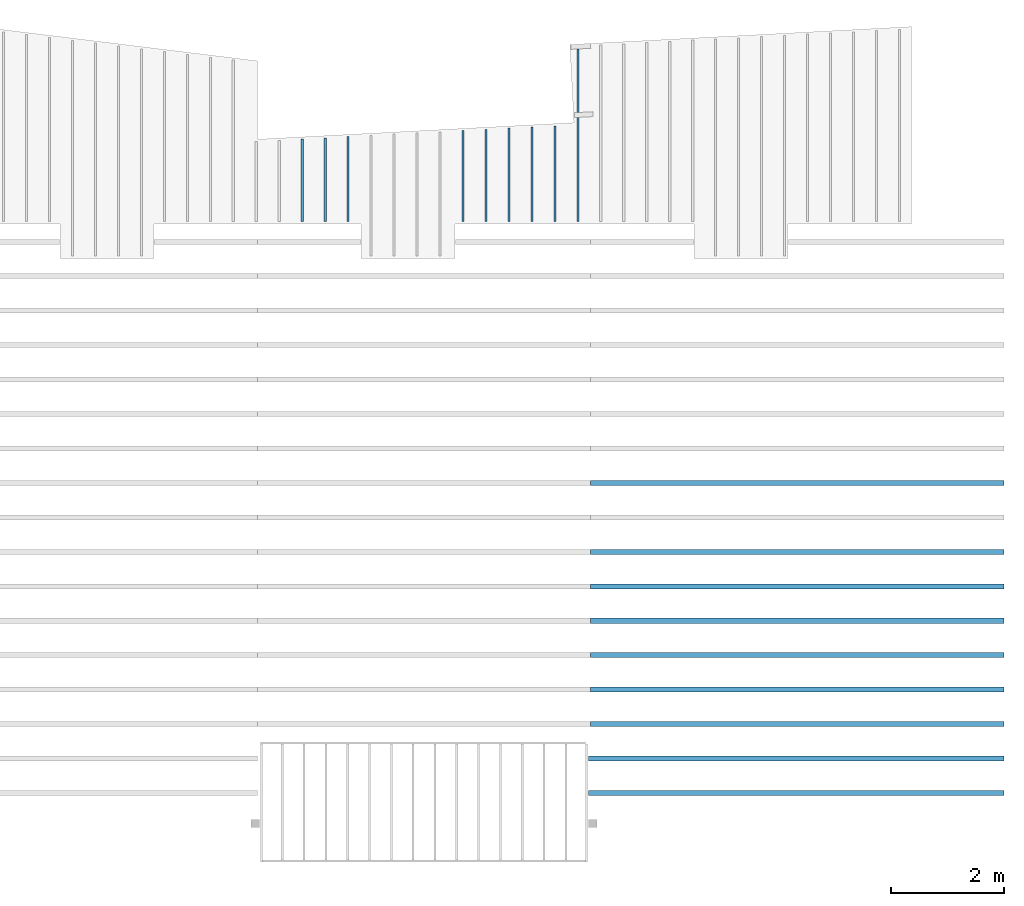
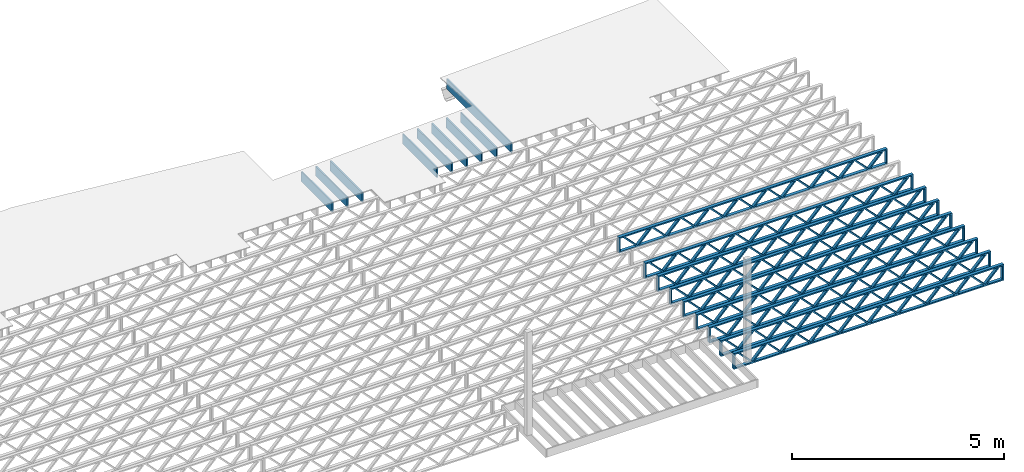
# One storey, part 10 of 12: 18 beams, 2 elements without a shape of their own.
"""IFC4 building model written with IfcOpenShell, lengths in feet."""

from ifc_helpers import new_model, entity, si_unit, converted_unit, derived_unit, direction, frame, frame_2d, origin, origin_2d_with_axis, place, context, subcontext, project, spatial, rectangle, extrude, source, transform, mapped, material, material_profile, profile_set, profile_usage, type_object, type_shapes, element, aggregate, save


model = new_model("IFC4")

# Units and contexts
model_context = context("Model", 3, precision=0.0001, world=origin(), true_north=direction((6.12303176911189e-17, 1.0)))
body_context = subcontext(model_context, "Body", "Model", "MODEL_VIEW")
ifc_project = project(units=[converted_unit("LENGTHUNIT", "FOOT", entity("IfcRatioMeasure", 0.3048), si_unit("LENGTHUNIT", "METRE"), dimensions=[1, 0, 0, 0, 0, 0, 0]), converted_unit("AREAUNIT", "SQUARE FOOT", entity("IfcRatioMeasure", 0.09290304), si_unit("AREAUNIT", "SQUARE_METRE"), dimensions=[2, 0, 0, 0, 0, 0, 0]), converted_unit("VOLUMEUNIT", "CUBIC FOOT", entity("IfcRatioMeasure", 0.028316846592), si_unit("VOLUMEUNIT", "CUBIC_METRE"), dimensions=[3, 0, 0, 0, 0, 0, 0]), converted_unit("PLANEANGLEUNIT", "DEGREE", entity("IfcRatioMeasure", 0.0174532925199433), si_unit("PLANEANGLEUNIT", "RADIAN"), dimensions=[0, 0, 0, 0, 0, 0, 0]), si_unit("MASSUNIT", "GRAM", prefix="KILO"), derived_unit("MASSDENSITYUNIT", [(si_unit("MASSUNIT", "GRAM", prefix="KILO"), 1), (si_unit("LENGTHUNIT", "METRE"), -3)]), derived_unit("MOMENTOFINERTIAUNIT", [(si_unit("LENGTHUNIT", "METRE"), 4)]), si_unit("TIMEUNIT", "SECOND"), si_unit("FREQUENCYUNIT", "HERTZ"), si_unit("THERMODYNAMICTEMPERATUREUNIT", "DEGREE_CELSIUS"), derived_unit("THERMALTRANSMITTANCEUNIT", [(si_unit("MASSUNIT", "GRAM", prefix="KILO"), 1), (si_unit("THERMODYNAMICTEMPERATUREUNIT", "KELVIN"), -1), (si_unit("TIMEUNIT", "SECOND"), -3)]), derived_unit("VOLUMETRICFLOWRATEUNIT", [(si_unit("LENGTHUNIT", "METRE"), 3), (si_unit("TIMEUNIT", "SECOND"), -1)]), si_unit("ELECTRICCURRENTUNIT", "AMPERE"), si_unit("ELECTRICVOLTAGEUNIT", "VOLT"), si_unit("POWERUNIT", "WATT"), si_unit("FORCEUNIT", "NEWTON"), si_unit("ILLUMINANCEUNIT", "LUX"), si_unit("LUMINOUSFLUXUNIT", "LUMEN"), si_unit("LUMINOUSINTENSITYUNIT", "CANDELA"), derived_unit("USERDEFINED", [(si_unit("MASSUNIT", "GRAM", prefix="KILO"), -1), (si_unit("LENGTHUNIT", "METRE"), -2), (si_unit("TIMEUNIT", "SECOND"), 3), (si_unit("LUMINOUSFLUXUNIT", "LUMEN"), 1)]), derived_unit("LINEARVELOCITYUNIT", [(si_unit("LENGTHUNIT", "METRE"), 1), (si_unit("TIMEUNIT", "SECOND"), -1)]), si_unit("PRESSUREUNIT", "PASCAL"), derived_unit("USERDEFINED", [(si_unit("LENGTHUNIT", "METRE"), -2), (si_unit("MASSUNIT", "GRAM", prefix="KILO"), 1), (si_unit("TIMEUNIT", "SECOND"), -2)]), derived_unit("LINEARFORCEUNIT", [(si_unit("MASSUNIT", "GRAM", prefix="KILO"), 1), (si_unit("LENGTHUNIT", "METRE"), 1), (si_unit("TIMEUNIT", "SECOND"), -2), (si_unit("LENGTHUNIT", "METRE"), -1)]), derived_unit("PLANARFORCEUNIT", [(si_unit("MASSUNIT", "GRAM", prefix="KILO"), 1), (si_unit("LENGTHUNIT", "METRE"), 1), (si_unit("TIMEUNIT", "SECOND"), -2), (si_unit("LENGTHUNIT", "METRE"), -2)])], contexts=[model_context])

# Site, building, storey
site_placement = place(None, origin())
site = spatial("IfcSite", under=ifc_project, at=site_placement, CompositionType="ELEMENT")
building_placement = place(site_placement, origin())
building = spatial("IfcBuilding", under=site, at=building_placement, CompositionType="ELEMENT")
storey_placement = place(building_placement, frame((0.0, 0.0, 21.46875)))
storey = spatial("IfcBuildingStorey", under=building, at=storey_placement, Name="3RD FLOOR", CompositionType="ELEMENT", Elevation=21.46875)

# Assembly, beams
assembly_1_placement = place(storey_placement, origin())
assembly_1 = element("IfcElementAssembly", 1, at=assembly_1_placement, inside=storey, Name="Structural Beam System:Structural Framing System", ObjectType="Structural Beam System:Structural Framing System", AssemblyPlace="NOTDEFINED", PredefinedType="BEAM_GRID")
ifc_material_1 = material(Name="WOOD TRUSS", Category="Materials")
ifc_material_profile_1 = material_profile(ifc_material_1, rectangle(XDim=1.73473973950632, YDim=0.125, at=frame_2d((-1.11022302462516e-16, 8.32667268468867e-17), x_axis=(1.0, 0.0))))
ifc_material_profile_2 = material_profile(ifc_material_1, rectangle(XDim=1.73473973950633, YDim=0.125, at=frame_2d((-1.11022302462516e-16, 8.32667268468867e-17), x_axis=(1.0, 0.0))))
ifc_material_profile_3 = material_profile(ifc_material_1, rectangle(XDim=1.73473973950632, YDim=0.125, at=frame_2d((-5.55111512312578e-17, 1.38777878078145e-16), x_axis=(1.0, 0.0))))
ifc_material_profile_4 = material_profile(ifc_material_1, rectangle(XDim=1.73473973950633, YDim=0.125, at=frame_2d((-1.11022302462516e-16, 8.32667268468867e-17), x_axis=(1.0, 0.0))))
ifc_material_profile_5 = material_profile(ifc_material_1, rectangle(XDim=1.73473973950632, YDim=0.125, at=frame_2d((-1.11022302462516e-16, 8.32667268468867e-17), x_axis=(1.0, 0.0))))
ifc_material_profile_6 = material_profile(ifc_material_1, rectangle(XDim=1.73473973950633, YDim=0.125, at=frame_2d((-2.77555756156289e-16, 3.05311331771918e-16), x_axis=(1.0, 0.0))))
ifc_material_profile_7 = material_profile(ifc_material_1, rectangle(XDim=1.73473973950632, YDim=0.124999999999999, at=frame_2d((-3.88578058618805e-16, -2.4980018054066e-16), x_axis=(1.0, 0.0))))
ifc_material_profile_8 = material_profile(ifc_material_1, rectangle(XDim=1.73473973950633, YDim=0.125, at=frame_2d((2.77555756156289e-16, -3.05311331771918e-16), x_axis=(1.0, 0.0))))
ifc_material_profile_9 = material_profile(ifc_material_1, rectangle(XDim=1.73473973950632, YDim=0.124999999999999, at=frame_2d((-1.11022302462516e-16, 8.32667268468867e-17), x_axis=(1.0, 0.0))))
ifc_material_profile_10 = material_profile(ifc_material_1, rectangle(XDim=1.73473973950633, YDim=0.125, at=origin_2d_with_axis()))
ifc_material_profile_11 = material_profile(ifc_material_1, rectangle(XDim=0.124999999999982, YDim=0.291666666666668, at=origin_2d_with_axis()))
ifc_material_profile_12 = material_profile(ifc_material_1, rectangle(XDim=0.124999999999932, YDim=0.291666666666664, at=origin_2d_with_axis()))
ifc_material_profile_13 = material_profile(ifc_material_1, rectangle(XDim=1.25000000000002, YDim=0.29166666666667, at=origin_2d_with_axis()))
ifc_material_profile_14 = material_profile(ifc_material_1, rectangle(XDim=1.25000000000004, YDim=0.291666666666667, at=origin_2d_with_axis()))
ifc_profile_set_1 = profile_set([ifc_material_profile_1, ifc_material_profile_2, ifc_material_profile_3, ifc_material_profile_4, ifc_material_profile_5, ifc_material_profile_6, ifc_material_profile_7, ifc_material_profile_8, ifc_material_profile_9, ifc_material_profile_10, ifc_material_profile_11, ifc_material_profile_12, ifc_material_profile_13, ifc_material_profile_14])
ifc_profile_usage_1 = profile_usage(ifc_profile_set_1, cardinal=8)
beam_type_1 = type_object("IfcBeamType", PredefinedType="BEAM", material=ifc_profile_set_1)
shared_shape_1 = source(origin(), body_context, "Body", "SweptSolid", [
    extrude(rectangle(XDim=1.73473973950632, YDim=0.124999999999999, at=frame_2d((5.55111512312578e-16, 7.21644966006352e-16), x_axis=(1.0, 0.0))), frame((8.37514585578398, -0.145833333333334, 0.0), z_axis=(0.0, 1.0, 0.0), x_axis=(0.693383046997606, 0.0, 0.720569184836762)), (0.0, 0.0, 1.0), 0.291666666666667),
    extrude(rectangle(XDim=1.73473973950633, YDim=0.125, at=origin_2d_with_axis()), frame((7.12485998211071, -0.145833333333334, 0.0), z_axis=(0.0, 1.0, 0.0), x_axis=(0.69338304699761, 0.0, -0.720569184836758)), (0.0, 0.0, 1.0), 0.291666666666666),
    extrude(rectangle(XDim=1.73473973950632, YDim=0.124999999999999, at=frame_2d((-1.11022302462516e-16, 8.32667268468867e-17), x_axis=(1.0, 0.0))), frame((5.79181154946831, -0.145833333333334, 0.0), z_axis=(0.0, 1.0, 0.0), x_axis=(0.693383046997606, 0.0, 0.720569184836762)), (0.0, 0.0, 1.0), 0.291666666666667),
    extrude(rectangle(XDim=1.73473973950633, YDim=0.125, at=origin_2d_with_axis()), frame((4.54152567579504, -0.145833333333334, 0.0), z_axis=(0.0, 1.0, 0.0), x_axis=(0.69338304699761, 0.0, -0.720569184836758)), (0.0, 0.0, 1.0), 0.291666666666666),
    extrude(rectangle(XDim=1.73473973950632, YDim=0.125, at=frame_2d((2.22044604925031e-16, 3.88578058618805e-16), x_axis=(1.0, 0.0))), frame((3.20847724315264, -0.145833333333334, 0.0), z_axis=(0.0, 1.0, 0.0), x_axis=(0.693383046997606, 0.0, 0.720569184836762)), (0.0, 0.0, 1.0), 0.291666666666667),
    extrude(rectangle(XDim=1.73473973950633, YDim=0.125, at=frame_2d((-1.11022302462516e-16, 8.32667268468867e-17), x_axis=(1.0, 0.0))), frame((1.95819136947937, -0.145833333333334, 0.0), z_axis=(0.0, 1.0, 0.0), x_axis=(0.69338304699761, 0.0, -0.720569184836758)), (0.0, 0.0, 1.0), 0.291666666666667),
    extrude(rectangle(XDim=1.73473973950632, YDim=0.125, at=frame_2d((-5.55111512312578e-17, 1.38777878078145e-16), x_axis=(1.0, 0.0))), frame((0.625142936836964, -0.145833333333334, 0.0), z_axis=(0.0, 1.0, 0.0), x_axis=(0.693383046997606, 0.0, 0.720569184836762)), (0.0, 0.0, 1.0), 0.291666666666667),
    extrude(rectangle(XDim=1.73473973950633, YDim=0.125, at=frame_2d((-1.11022302462516e-16, 8.32667268468867e-17), x_axis=(1.0, 0.0))), frame((-0.625142936836306, -0.145833333333334, 0.0), z_axis=(0.0, 1.0, 0.0), x_axis=(0.69338304699761, 0.0, -0.720569184836758)), (0.0, 0.0, 1.0), 0.291666666666667),
    extrude(rectangle(XDim=1.73473973950632, YDim=0.125, at=frame_2d((-1.11022302462516e-16, 8.32667268468867e-17), x_axis=(1.0, 0.0))), frame((-1.95819136947871, -0.145833333333334, 0.0), z_axis=(0.0, 1.0, 0.0), x_axis=(0.693383046997606, 0.0, 0.720569184836762)), (0.0, 0.0, 1.0), 0.291666666666667),
    extrude(rectangle(XDim=1.73473973950633, YDim=0.125, at=origin_2d_with_axis()), frame((-3.20847724315198, -0.145833333333334, 0.0), z_axis=(0.0, 1.0, 0.0), x_axis=(0.69338304699761, 0.0, -0.720569184836758)), (0.0, 0.0, 1.0), 0.291666666666667),
    extrude(rectangle(XDim=1.73473973950632, YDim=0.124999999999999, at=frame_2d((-1.11022302462516e-16, 8.32667268468867e-17), x_axis=(1.0, 0.0))), frame((-4.54152567579438, -0.145833333333334, 0.0), z_axis=(0.0, 1.0, 0.0), x_axis=(0.693383046997606, 0.0, 0.720569184836762)), (0.0, 0.0, 1.0), 0.291666666666667),
    extrude(rectangle(XDim=1.73473973950633, YDim=0.125, at=origin_2d_with_axis()), frame((-5.79181154946765, -0.145833333333334, 0.0), z_axis=(0.0, 1.0, 0.0), x_axis=(0.69338304699761, 0.0, -0.720569184836758)), (0.0, 0.0, 1.0), 0.291666666666666),
    extrude(rectangle(XDim=1.73473973950632, YDim=0.124999999999999, at=frame_2d((-1.11022302462516e-16, 8.32667268468867e-17), x_axis=(1.0, 0.0))), frame((-7.12485998211005, -0.145833333333334, 0.0), z_axis=(0.0, 1.0, 0.0), x_axis=(0.693383046997606, 0.0, 0.720569184836762)), (0.0, 0.0, 1.0), 0.291666666666667),
    extrude(rectangle(XDim=1.73473973950633, YDim=0.125, at=frame_2d((-2.77555756156289e-16, 3.05311331771918e-16), x_axis=(1.0, 0.0))), frame((-8.37514585578332, -0.145833333333334, 0.0), z_axis=(0.0, 1.0, 0.0), x_axis=(0.69338304699761, 0.0, -0.720569184836758)), (0.0, 0.0, 1.0), 0.291666666666666),
    extrude(rectangle(XDim=1.73473973950632, YDim=0.125, at=frame_2d((-7.21644966006352e-16, -5.55111512312578e-16), x_axis=(1.0, 0.0))), frame((10.9584801620997, -0.145833333333334, 0.0), z_axis=(0.0, 1.0, 0.0), x_axis=(0.693383046997606, 0.0, 0.720569184836762)), (0.0, 0.0, 1.0), 0.291666666666667),
    extrude(rectangle(XDim=1.73473973950633, YDim=0.125, at=origin_2d_with_axis()), frame((9.70819428842638, -0.145833333333334, 0.0), z_axis=(0.0, 1.0, 0.0), x_axis=(0.69338304699761, 0.0, -0.720569184836758)), (0.0, 0.0, 1.0), 0.291666666666666),
    extrude(rectangle(XDim=1.73473973950632, YDim=0.125, at=frame_2d((-5.55111512312578e-17, 8.32667268468867e-17), x_axis=(1.0, 0.0))), frame((-9.70819428842572, -0.145833333333334, 0.0), z_axis=(0.0, 1.0, 0.0), x_axis=(0.693383046997606, 0.0, 0.720569184836762)), (0.0, 0.0, 1.0), 0.291666666666667),
    extrude(rectangle(XDim=1.73473973950633, YDim=0.125, at=origin_2d_with_axis()), frame((-10.958480162099, -0.145833333333334, 0.0), z_axis=(0.0, 1.0, 0.0), x_axis=(0.69338304699761, 0.0, -0.720569184836758)), (0.0, 0.0, 1.0), 0.291666666666666),
    extrude(rectangle(XDim=0.124999999999982, YDim=0.291666666666668, at=origin_2d_with_axis()), frame((-12.0000038919293, 0.0, 0.687500000000054), z_axis=(1.0, 0.0, 0.0), x_axis=(0.0, 0.0, -1.0)), (0.0, 0.0, 1.0), 24.0000077838585),
    extrude(rectangle(XDim=0.124999999999932, YDim=0.291666666666664, at=origin_2d_with_axis()), frame((-12.0000038919291, 0.0, -0.687499999999984), z_axis=(1.0, 0.0, 0.0), x_axis=(0.0, 0.0, -1.0)), (0.0, 0.0, 1.0), 24.0000077838583),
    extrude(rectangle(XDim=1.25000000000002, YDim=0.29166666666667, at=origin_2d_with_axis()), frame((11.8750038919292, 0.0, 0.0), z_axis=(1.0, 0.0, 0.0), x_axis=(0.0, 0.0, -1.0)), (0.0, 0.0, 1.0), 0.12500000000002),
    extrude(rectangle(XDim=1.25000000000004, YDim=0.291666666666667, at=origin_2d_with_axis()), frame((-12.0000038919293, 0.0, 0.0), z_axis=(1.0, 0.0, 0.0), x_axis=(0.0, 0.0, -1.0)), (0.0, 0.0, 1.0), 0.125000000000023),
])
type_shapes(beam_type_1, [shared_shape_1])
beam_1_placement = place(assembly_1_placement, frame((-152.404823260266, 943.861934882651, -0.947916666657864), z_axis=(0.0, 0.0, 1.0), x_axis=(-1.0, 0.0, 0.0)))
beam_1 = element("IfcBeam", 2, at=beam_1_placement, type_object=beam_type_1, material=ifc_profile_usage_1, PredefinedType="BEAM", context=body_context, shape_type="MappedRepresentation", body=[
    mapped(shared_shape_1, transform((0.0, 0.0, 0.0), scale=1.0)),
])
ifc_profile_usage_2 = profile_usage(ifc_profile_set_1, cardinal=8)
beam_2_placement = place(assembly_1_placement, frame((-152.404823260266, 939.861934882651, -0.947916666657864), z_axis=(0.0, 0.0, 1.0), x_axis=(-1.0, 0.0, 0.0)))
beam_2 = element("IfcBeam", 3, at=beam_2_placement, type_object=beam_type_1, material=ifc_profile_usage_2, PredefinedType="BEAM", context=body_context, shape_type="MappedRepresentation", body=[
    mapped(shared_shape_1, transform((0.0, 0.0, 0.0), scale=1.0)),
])
ifc_profile_usage_3 = profile_usage(ifc_profile_set_1, cardinal=8)
beam_3_placement = place(assembly_1_placement, frame((-152.404823260266, 937.861934882651, -0.947916666657864), z_axis=(0.0, 0.0, 1.0), x_axis=(-1.0, 0.0, 0.0)))
beam_3 = element("IfcBeam", 4, at=beam_3_placement, type_object=beam_type_1, material=ifc_profile_usage_3, PredefinedType="BEAM", context=body_context, shape_type="MappedRepresentation", body=[
    mapped(shared_shape_1, transform((0.0, 0.0, 0.0), scale=1.0)),
])
ifc_profile_usage_4 = profile_usage(ifc_profile_set_1, cardinal=8)
beam_4_placement = place(assembly_1_placement, frame((-152.404823260266, 935.861934882651, -0.947916666657864), z_axis=(0.0, 0.0, 1.0), x_axis=(-1.0, 0.0, 0.0)))
beam_4 = element("IfcBeam", 5, at=beam_4_placement, type_object=beam_type_1, material=ifc_profile_usage_4, PredefinedType="BEAM", context=body_context, shape_type="MappedRepresentation", body=[
    mapped(shared_shape_1, transform((0.0, 0.0, 0.0), scale=1.0)),
])
ifc_profile_usage_5 = profile_usage(ifc_profile_set_1, cardinal=8)
beam_5_placement = place(assembly_1_placement, frame((-152.404823260266, 933.861934882651, -0.947916666657864), z_axis=(0.0, 0.0, 1.0), x_axis=(-1.0, 0.0, 0.0)))
beam_5 = element("IfcBeam", 6, at=beam_5_placement, type_object=beam_type_1, material=ifc_profile_usage_5, PredefinedType="BEAM", context=body_context, shape_type="MappedRepresentation", body=[
    mapped(shared_shape_1, transform((0.0, 0.0, 0.0), scale=1.0)),
])
ifc_profile_usage_6 = profile_usage(ifc_profile_set_1, cardinal=8)
beam_6_placement = place(assembly_1_placement, frame((-152.404823260266, 931.861934882651, -0.947916666657864), z_axis=(0.0, 0.0, 1.0), x_axis=(-1.0, 0.0, 0.0)))
beam_6 = element("IfcBeam", 7, at=beam_6_placement, type_object=beam_type_1, material=ifc_profile_usage_6, PredefinedType="BEAM", context=body_context, shape_type="MappedRepresentation", body=[
    mapped(shared_shape_1, transform((0.0, 0.0, 0.0), scale=1.0)),
])
ifc_profile_usage_7 = profile_usage(ifc_profile_set_1, cardinal=8)
beam_7_placement = place(assembly_1_placement, frame((-152.404823260266, 929.861934882651, -0.947916666657864), z_axis=(0.0, 0.0, 1.0), x_axis=(-1.0, 0.0, 0.0)))
beam_7 = element("IfcBeam", 8, at=beam_7_placement, type_object=beam_type_1, material=ifc_profile_usage_7, PredefinedType="BEAM", context=body_context, shape_type="MappedRepresentation", body=[
    mapped(shared_shape_1, transform((0.0, 0.0, 0.0), scale=1.0)),
])
ifc_profile_usage_8 = profile_usage(ifc_profile_set_1, cardinal=8)
beam_type_2 = type_object("IfcBeamType", PredefinedType="BEAM", material=ifc_profile_set_1)
shared_shape_2 = source(origin(), body_context, "Body", "SweptSolid", [
    extrude(rectangle(XDim=1.73473973950632, YDim=0.124999999999999, at=frame_2d((5.55111512312578e-16, 7.21644966006352e-16), x_axis=(1.0, 0.0))), frame((8.42202085580899, -0.145833333333334, 0.0), z_axis=(0.0, 1.0, 0.0), x_axis=(0.693383046997606, 0.0, 0.720569184836762)), (0.0, 0.0, 1.0), 0.291666666666667),
    extrude(rectangle(XDim=1.73473973950633, YDim=0.125, at=origin_2d_with_axis()), frame((7.17173498213572, -0.145833333333334, 0.0), z_axis=(0.0, 1.0, 0.0), x_axis=(0.69338304699761, 0.0, -0.720569184836758)), (0.0, 0.0, 1.0), 0.291666666666666),
    extrude(rectangle(XDim=1.73473973950632, YDim=0.124999999999999, at=frame_2d((-1.11022302462516e-16, 8.32667268468867e-17), x_axis=(1.0, 0.0))), frame((5.82306154948498, -0.145833333333334, 0.0), z_axis=(0.0, 1.0, 0.0), x_axis=(0.693383046997606, 0.0, 0.720569184836762)), (0.0, 0.0, 1.0), 0.291666666666667),
    extrude(rectangle(XDim=1.73473973950633, YDim=0.125, at=origin_2d_with_axis()), frame((4.57277567581171, -0.145833333333334, 0.0), z_axis=(0.0, 1.0, 0.0), x_axis=(0.69338304699761, 0.0, -0.720569184836758)), (0.0, 0.0, 1.0), 0.291666666666666),
    extrude(rectangle(XDim=1.73473973950632, YDim=0.125, at=frame_2d((2.22044604925031e-16, 3.88578058618805e-16), x_axis=(1.0, 0.0))), frame((3.22410224316097, -0.145833333333334, 0.0), z_axis=(0.0, 1.0, 0.0), x_axis=(0.693383046997606, 0.0, 0.720569184836762)), (0.0, 0.0, 1.0), 0.291666666666667),
    extrude(rectangle(XDim=1.73473973950633, YDim=0.125, at=frame_2d((-1.11022302462516e-16, 8.32667268468867e-17), x_axis=(1.0, 0.0))), frame((1.9738163694877, -0.145833333333334, 0.0), z_axis=(0.0, 1.0, 0.0), x_axis=(0.69338304699761, 0.0, -0.720569184836758)), (0.0, 0.0, 1.0), 0.291666666666667),
    extrude(rectangle(XDim=1.73473973950632, YDim=0.125, at=frame_2d((-5.55111512312578e-17, 1.38777878078145e-16), x_axis=(1.0, 0.0))), frame((0.625142936836964, -0.145833333333334, 0.0), z_axis=(0.0, 1.0, 0.0), x_axis=(0.693383046997606, 0.0, 0.720569184836762)), (0.0, 0.0, 1.0), 0.291666666666667),
    extrude(rectangle(XDim=1.73473973950633, YDim=0.125, at=frame_2d((-1.11022302462516e-16, 8.32667268468867e-17), x_axis=(1.0, 0.0))), frame((-0.625142936836306, -0.145833333333334, 0.0), z_axis=(0.0, 1.0, 0.0), x_axis=(0.69338304699761, 0.0, -0.720569184836758)), (0.0, 0.0, 1.0), 0.291666666666667),
    extrude(rectangle(XDim=1.73473973950632, YDim=0.125, at=frame_2d((-1.11022302462516e-16, 8.32667268468867e-17), x_axis=(1.0, 0.0))), frame((-1.97381636948704, -0.145833333333334, 0.0), z_axis=(0.0, 1.0, 0.0), x_axis=(0.693383046997606, 0.0, 0.720569184836762)), (0.0, 0.0, 1.0), 0.291666666666667),
    extrude(rectangle(XDim=1.73473973950633, YDim=0.125, at=origin_2d_with_axis()), frame((-3.22410224316031, -0.145833333333334, 0.0), z_axis=(0.0, 1.0, 0.0), x_axis=(0.69338304699761, 0.0, -0.720569184836758)), (0.0, 0.0, 1.0), 0.291666666666667),
    extrude(rectangle(XDim=1.73473973950632, YDim=0.124999999999999, at=frame_2d((-1.11022302462516e-16, 8.32667268468867e-17), x_axis=(1.0, 0.0))), frame((-4.57277567581105, -0.145833333333334, 0.0), z_axis=(0.0, 1.0, 0.0), x_axis=(0.693383046997606, 0.0, 0.720569184836762)), (0.0, 0.0, 1.0), 0.291666666666667),
    extrude(rectangle(XDim=1.73473973950633, YDim=0.125, at=origin_2d_with_axis()), frame((-5.82306154948432, -0.145833333333334, 0.0), z_axis=(0.0, 1.0, 0.0), x_axis=(0.69338304699761, 0.0, -0.720569184836758)), (0.0, 0.0, 1.0), 0.291666666666666),
    extrude(rectangle(XDim=1.73473973950632, YDim=0.124999999999999, at=frame_2d((-1.11022302462516e-16, 8.32667268468867e-17), x_axis=(1.0, 0.0))), frame((-7.17173498213506, -0.145833333333334, 0.0), z_axis=(0.0, 1.0, 0.0), x_axis=(0.693383046997606, 0.0, 0.720569184836762)), (0.0, 0.0, 1.0), 0.291666666666667),
    extrude(rectangle(XDim=1.73473973950633, YDim=0.125, at=frame_2d((-2.77555756156289e-16, 3.05311331771918e-16), x_axis=(1.0, 0.0))), frame((-8.42202085580833, -0.145833333333334, 0.0), z_axis=(0.0, 1.0, 0.0), x_axis=(0.69338304699761, 0.0, -0.720569184836758)), (0.0, 0.0, 1.0), 0.291666666666666),
    extrude(rectangle(XDim=1.73473973950632, YDim=0.125, at=frame_2d((-7.21644966006352e-16, -5.55111512312578e-16), x_axis=(1.0, 0.0))), frame((11.020980162133, -0.145833333333334, 0.0), z_axis=(0.0, 1.0, 0.0), x_axis=(0.693383046997606, 0.0, 0.720569184836762)), (0.0, 0.0, 1.0), 0.291666666666667),
    extrude(rectangle(XDim=1.73473973950633, YDim=0.125, at=origin_2d_with_axis()), frame((9.77069428845972, -0.145833333333334, 0.0), z_axis=(0.0, 1.0, 0.0), x_axis=(0.69338304699761, 0.0, -0.720569184836758)), (0.0, 0.0, 1.0), 0.291666666666666),
    extrude(rectangle(XDim=1.73473973950632, YDim=0.125, at=frame_2d((-5.55111512312578e-17, 8.32667268468867e-17), x_axis=(1.0, 0.0))), frame((-9.77069428845906, -0.145833333333334, 0.0), z_axis=(0.0, 1.0, 0.0), x_axis=(0.693383046997606, 0.0, 0.720569184836762)), (0.0, 0.0, 1.0), 0.291666666666667),
    extrude(rectangle(XDim=1.73473973950633, YDim=0.125, at=origin_2d_with_axis()), frame((-11.0209801621323, -0.145833333333334, 0.0), z_axis=(0.0, 1.0, 0.0), x_axis=(0.69338304699761, 0.0, -0.720569184836758)), (0.0, 0.0, 1.0), 0.291666666666666),
    extrude(rectangle(XDim=0.124999999999982, YDim=0.291666666666668, at=origin_2d_with_axis()), frame((-12.0625038919626, 0.0, 0.687500000000054), z_axis=(1.0, 0.0, 0.0), x_axis=(0.0, 0.0, -1.0)), (0.0, 0.0, 1.0), 24.1250077839252),
    extrude(rectangle(XDim=0.124999999999932, YDim=0.291666666666664, at=origin_2d_with_axis()), frame((-12.0625038919624, 0.0, -0.687499999999984), z_axis=(1.0, 0.0, 0.0), x_axis=(0.0, 0.0, -1.0)), (0.0, 0.0, 1.0), 24.125007783925),
    extrude(rectangle(XDim=1.25000000000002, YDim=0.29166666666667, at=origin_2d_with_axis()), frame((11.9375038919626, 0.0, 0.0), z_axis=(1.0, 0.0, 0.0), x_axis=(0.0, 0.0, -1.0)), (0.0, 0.0, 1.0), 0.12500000000002),
    extrude(rectangle(XDim=1.25000000000004, YDim=0.291666666666667, at=origin_2d_with_axis()), frame((-12.0625038919626, 0.0, 0.0), z_axis=(1.0, 0.0, 0.0), x_axis=(0.0, 0.0, -1.0)), (0.0, 0.0, 1.0), 0.125000000000023),
])
type_shapes(beam_type_2, [shared_shape_2])
beam_8_placement = place(assembly_1_placement, frame((-152.467323260299, 927.861934882651, -0.947916666657864), z_axis=(0.0, 0.0, 1.0), x_axis=(-1.0, 0.0, 0.0)))
beam_8 = element("IfcBeam", 9, at=beam_8_placement, type_object=beam_type_2, material=ifc_profile_usage_8, PredefinedType="BEAM", context=body_context, shape_type="MappedRepresentation", body=[
    mapped(shared_shape_2, transform((0.0, 0.0, 0.0), scale=1.0)),
])
ifc_profile_usage_9 = profile_usage(ifc_profile_set_1, cardinal=8)
beam_9_placement = place(assembly_1_placement, frame((-152.467323260299, 925.861934882651, -0.947916666657864), z_axis=(0.0, 0.0, 1.0), x_axis=(-1.0, 0.0, 0.0)))
beam_9 = element("IfcBeam", 10, at=beam_9_placement, type_object=beam_type_2, material=ifc_profile_usage_9, PredefinedType="BEAM", context=body_context, shape_type="MappedRepresentation", body=[
    mapped(shared_shape_2, transform((0.0, 0.0, 0.0), scale=1.0)),
])
aggregate(assembly_1, [beam_1, beam_2, beam_3, beam_4, beam_5, beam_6, beam_7, beam_8, beam_9])

assembly_2_placement = place(storey_placement, origin())
assembly_2 = element("IfcElementAssembly", 11, at=assembly_2_placement, inside=storey, Name="Structural Beam System:Structural Framing System", ObjectType="Structural Beam System:Structural Framing System", AssemblyPlace="NOTDEFINED", PredefinedType="BEAM_GRID")
ifc_material_2 = material(Category="Materials")
ifc_material_profile_15 = material_profile(ifc_material_2, rectangle(XDim=0.9375, YDim=0.125000000000011, at=origin_2d_with_axis()))
ifc_profile_set_2 = profile_set([ifc_material_profile_15])
ifc_profile_usage_10 = profile_usage(ifc_profile_set_2, cardinal=8)
beam_type_3 = type_object("IfcBeamType", PredefinedType="BEAM", material=ifc_profile_set_2)
shared_shape_3 = source(origin(), body_context, "Body", "SweptSolid", [
    extrude(rectangle(XDim=0.9375, YDim=0.125000000000011, at=origin_2d_with_axis()), frame((-2.39810171735763, 0.0, 0.0), z_axis=(1.0, 0.0, 0.0), x_axis=(0.0, 0.0, -1.0)), (0.0, 0.0, 1.0), 4.79620343471527),
])
type_shapes(beam_type_3, [shared_shape_3])
beam_10_placement = place(assembly_2_placement, frame((-181.144289395965, 961.426701238825, -0.729166666666714), z_axis=(0.0, 0.0, 1.0), x_axis=(0.0, 1.0, 0.0)))
beam_10 = element("IfcBeam", 12, at=beam_10_placement, type_object=beam_type_3, material=ifc_profile_usage_10, PredefinedType="BEAM", context=body_context, shape_type="MappedRepresentation", body=[
    mapped(shared_shape_3, transform((0.0, 0.0, 0.0), scale=1.0)),
])
ifc_profile_usage_11 = profile_usage(ifc_profile_set_2, cardinal=8)
beam_type_4 = type_object("IfcBeamType", PredefinedType="BEAM", material=ifc_profile_set_2)
shared_shape_4 = source(origin(), body_context, "Body", "SweptSolid", [
    extrude(rectangle(XDim=0.9375, YDim=0.125000000000011, at=origin_2d_with_axis()), frame((-2.43304040438079, 0.0, 0.0), z_axis=(1.0, 0.0, 0.0), x_axis=(0.0, 0.0, -1.0)), (0.0, 0.0, 1.0), 4.86608080876158),
])
type_shapes(beam_type_4, [shared_shape_4])
beam_11_placement = place(assembly_2_placement, frame((-179.810956062631, 961.461639590845, -0.729166666666714), z_axis=(0.0, 0.0, 1.0), x_axis=(0.0, 1.0, 0.0)))
beam_11 = element("IfcBeam", 13, at=beam_11_placement, type_object=beam_type_4, material=ifc_profile_usage_11, PredefinedType="BEAM", context=body_context, shape_type="MappedRepresentation", body=[
    mapped(shared_shape_4, transform((0.0, 0.0, 0.0), scale=1.0)),
])
ifc_profile_usage_12 = profile_usage(ifc_profile_set_2, cardinal=8)
beam_type_5 = type_object("IfcBeamType", PredefinedType="BEAM", material=ifc_profile_set_2)
shared_shape_5 = source(origin(), body_context, "Body", "SweptSolid", [
    extrude(rectangle(XDim=0.9375, YDim=0.125000000000011, at=origin_2d_with_axis()), frame((-2.467979091404, 0.0, 0.0), z_axis=(1.0, 0.0, 0.0), x_axis=(0.0, 0.0, -1.0)), (0.0, 0.0, 1.0), 4.93595818280801),
])
type_shapes(beam_type_5, [shared_shape_5])
beam_12_placement = place(assembly_2_placement, frame((-178.477622729298, 961.496577942866, -0.729166666666714), z_axis=(0.0, 0.0, 1.0), x_axis=(0.0, 1.0, 0.0)))
beam_12 = element("IfcBeam", 14, at=beam_12_placement, type_object=beam_type_5, material=ifc_profile_usage_12, PredefinedType="BEAM", context=body_context, shape_type="MappedRepresentation", body=[
    mapped(shared_shape_5, transform((0.0, 0.0, 0.0), scale=1.0)),
])
ifc_profile_usage_13 = profile_usage(ifc_profile_set_2, cardinal=8)
beam_type_6 = type_object("IfcBeamType", PredefinedType="BEAM", material=ifc_profile_set_2)
shared_shape_6 = source(origin(), body_context, "Body", "SweptSolid", [
    extrude(rectangle(XDim=0.9375, YDim=0.125000000000011, at=origin_2d_with_axis()), frame((-2.64267229354266, 0.0, 0.0), z_axis=(1.0, 0.0, 0.0), x_axis=(0.0, 0.0, -1.0)), (0.0, 0.0, 1.0), 5.28534458708532),
])
type_shapes(beam_type_6, [shared_shape_6])
beam_13_placement = place(assembly_2_placement, frame((-171.810956062631, 961.671269935947, -0.729166666666714), z_axis=(0.0, 0.0, 1.0), x_axis=(0.0, 1.0, 0.0)))
beam_13 = element("IfcBeam", 15, at=beam_13_placement, type_object=beam_type_6, material=ifc_profile_usage_13, PredefinedType="BEAM", context=body_context, shape_type="MappedRepresentation", body=[
    mapped(shared_shape_6, transform((0.0, 0.0, 0.0), scale=1.0)),
])
ifc_profile_usage_14 = profile_usage(ifc_profile_set_2, cardinal=8)
beam_type_7 = type_object("IfcBeamType", PredefinedType="BEAM", material=ifc_profile_set_2)
shared_shape_7 = source(origin(), body_context, "Body", "SweptSolid", [
    extrude(rectangle(XDim=0.9375, YDim=0.125000000000011, at=origin_2d_with_axis()), frame((-2.67761064556333, 0.0, 0.0), z_axis=(1.0, 0.0, 0.0), x_axis=(0.0, 0.0, -1.0)), (0.0, 0.0, 1.0), 5.35522129112667),
])
type_shapes(beam_type_7, [shared_shape_7])
beam_14_placement = place(assembly_2_placement, frame((-170.477622729298, 961.70620862297, -0.729166666666714), z_axis=(0.0, 0.0, 1.0), x_axis=(0.0, 1.0, 0.0)))
beam_14 = element("IfcBeam", 16, at=beam_14_placement, type_object=beam_type_7, material=ifc_profile_usage_14, PredefinedType="BEAM", context=body_context, shape_type="MappedRepresentation", body=[
    mapped(shared_shape_7, transform((0.0, 0.0, 0.0), scale=1.0)),
])
ifc_profile_usage_15 = profile_usage(ifc_profile_set_2, cardinal=8)
beam_type_8 = type_object("IfcBeamType", PredefinedType="BEAM", material=ifc_profile_set_2)
shared_shape_8 = source(origin(), body_context, "Body", "SweptSolid", [
    extrude(rectangle(XDim=0.9375, YDim=0.125000000000011, at=origin_2d_with_axis()), frame((-2.71254899758407, 0.0, 0.0), z_axis=(1.0, 0.0, 0.0), x_axis=(0.0, 0.0, -1.0)), (0.0, 0.0, 1.0), 5.42509799516813),
])
type_shapes(beam_type_8, [shared_shape_8])
beam_15_placement = place(assembly_2_placement, frame((-169.144289395965, 961.741147309993, -0.729166666666714), z_axis=(0.0, 0.0, 1.0), x_axis=(0.0, 1.0, 0.0)))
beam_15 = element("IfcBeam", 17, at=beam_15_placement, type_object=beam_type_8, material=ifc_profile_usage_15, PredefinedType="BEAM", context=body_context, shape_type="MappedRepresentation", body=[
    mapped(shared_shape_8, transform((0.0, 0.0, 0.0), scale=1.0)),
])
ifc_profile_usage_16 = profile_usage(ifc_profile_set_2, cardinal=8)
beam_type_9 = type_object("IfcBeamType", PredefinedType="BEAM", material=ifc_profile_set_2)
shared_shape_9 = source(origin(), body_context, "Body", "SweptSolid", [
    extrude(rectangle(XDim=0.9375, YDim=0.125000000000011, at=origin_2d_with_axis()), frame((-2.74748734960474, 0.0, 0.0), z_axis=(1.0, 0.0, 0.0), x_axis=(0.0, 0.0, -1.0)), (0.0, 0.0, 1.0), 5.49497469920948),
])
type_shapes(beam_type_9, [shared_shape_9])
beam_16_placement = place(assembly_2_placement, frame((-167.810956062631, 961.776085997016, -0.729166666666714), z_axis=(0.0, 0.0, 1.0), x_axis=(0.0, 1.0, 0.0)))
beam_16 = element("IfcBeam", 18, at=beam_16_placement, type_object=beam_type_9, material=ifc_profile_usage_16, PredefinedType="BEAM", context=body_context, shape_type="MappedRepresentation", body=[
    mapped(shared_shape_9, transform((0.0, 0.0, 0.0), scale=1.0)),
])
ifc_profile_usage_17 = profile_usage(ifc_profile_set_2, cardinal=8)
beam_type_10 = type_object("IfcBeamType", PredefinedType="BEAM", material=ifc_profile_set_2)
shared_shape_10 = source(origin(), body_context, "Body", "SweptSolid", [
    extrude(rectangle(XDim=0.9375, YDim=0.125000000000011, at=origin_2d_with_axis()), frame((-2.78242570162547, 0.0, 0.0), z_axis=(1.0, 0.0, 0.0), x_axis=(0.0, 0.0, -1.0)), (0.0, 0.0, 1.0), 5.56485140325094),
])
type_shapes(beam_type_10, [shared_shape_10])
beam_17_placement = place(assembly_2_placement, frame((-166.477622729298, 961.811024684039, -0.729166666666714), z_axis=(0.0, 0.0, 1.0), x_axis=(0.0, 1.0, 0.0)))
beam_17 = element("IfcBeam", 19, at=beam_17_placement, type_object=beam_type_10, material=ifc_profile_usage_17, PredefinedType="BEAM", context=body_context, shape_type="MappedRepresentation", body=[
    mapped(shared_shape_10, transform((0.0, 0.0, 0.0), scale=1.0)),
])
ifc_profile_usage_18 = profile_usage(ifc_profile_set_2, cardinal=8)
beam_type_11 = type_object("IfcBeamType", PredefinedType="BEAM", material=ifc_profile_set_2)
shared_shape_11 = source(origin(), body_context, "Body", "SweptSolid", [
    extrude(rectangle(XDim=0.9375, YDim=0.125000000000011, at=origin_2d_with_axis()), frame((-5.12102117510278, 0.0, 0.0), z_axis=(1.0, 0.0, 0.0), x_axis=(0.0, 0.0, -1.0)), (0.0, 0.0, 1.0), 10.0208014833547),
])
type_shapes(beam_type_11, [shared_shape_11])
beam_18_placement = place(assembly_2_placement, frame((-165.144289386034, 964.149620416103, -0.729166666666714), z_axis=(0.0, 0.0, 1.0), x_axis=(0.0, 1.0, 0.0)))
beam_18 = element("IfcBeam", 20, at=beam_18_placement, type_object=beam_type_11, material=ifc_profile_usage_18, PredefinedType="BEAM", context=body_context, shape_type="MappedRepresentation", body=[
    mapped(shared_shape_11, transform((0.0, 0.0, 0.0), scale=1.0)),
])
aggregate(assembly_2, [beam_10, beam_11, beam_12, beam_13, beam_14, beam_15, beam_16, beam_17, beam_18])

save(model, "model.ifc")
